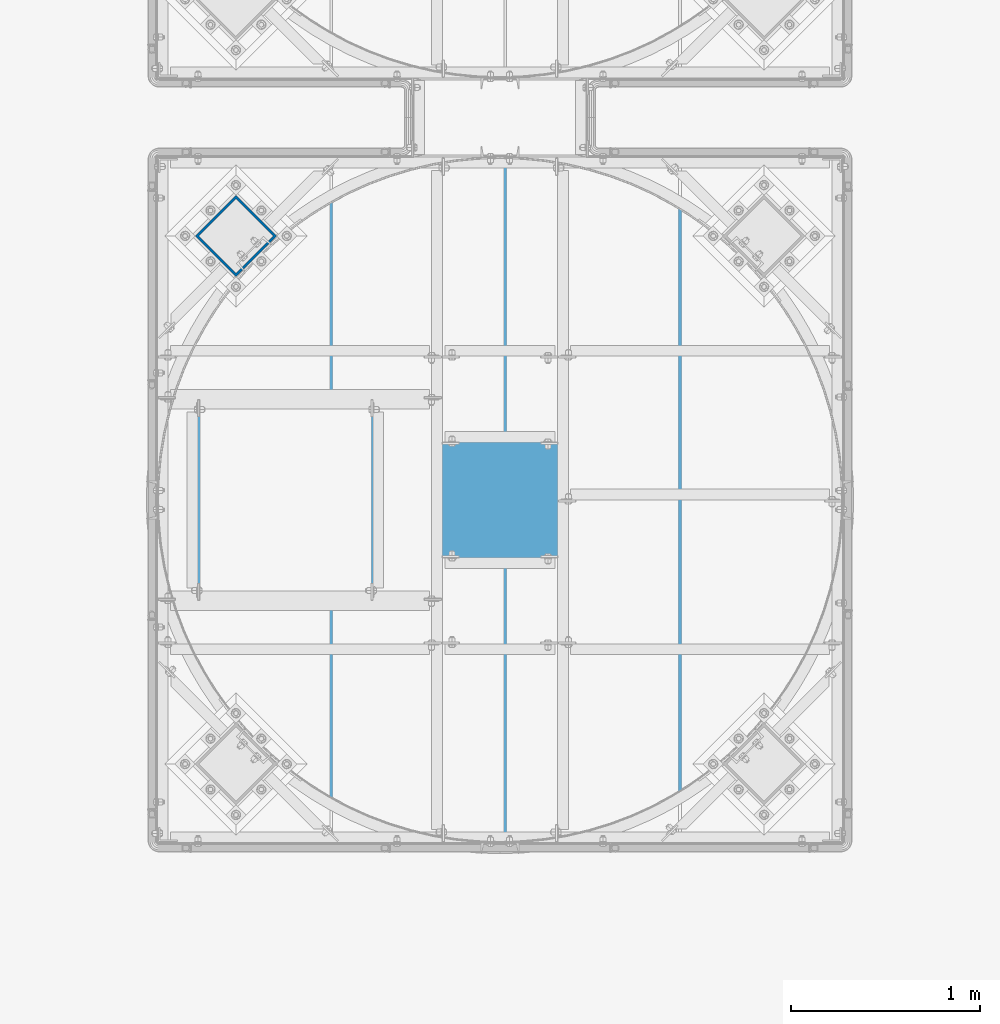
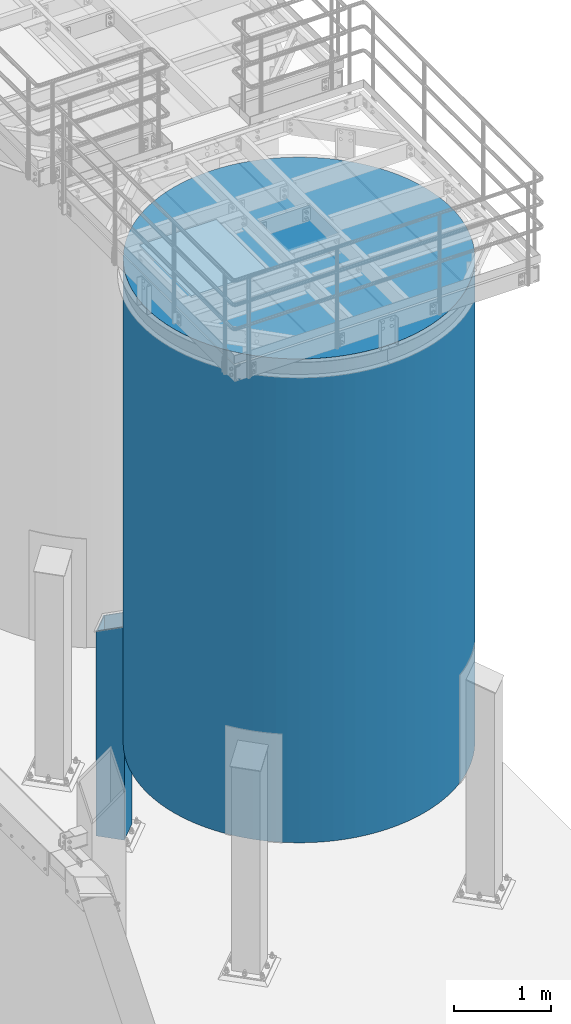
# One storey, part 548 of 1876: 2 columns, 2 elements without a shape of their own.
"""IFC2X3 building model written with IfcOpenShell, lengths in millimetres."""

from ifc_helpers import new_model, si_unit, frame, origin_with_axes, place, context, subcontext, project, spatial, faceted_brep, material, type_object, element, aggregate, save


model = new_model("IFC2X3")

# Units and contexts
model_context = context("Model", 3, precision=1e-05, world=origin_with_axes())
body_context = subcontext(model_context, "Body", "Model", "MODEL_VIEW")
ifc_project = project(units=[si_unit("LENGTHUNIT", "METRE", prefix="MILLI"), si_unit("AREAUNIT", "SQUARE_METRE"), si_unit("VOLUMEUNIT", "CUBIC_METRE"), si_unit("MASSUNIT", "GRAM", prefix="KILO"), si_unit("TIMEUNIT", "SECOND"), si_unit("PLANEANGLEUNIT", "RADIAN"), si_unit("SOLIDANGLEUNIT", "STERADIAN"), si_unit("THERMODYNAMICTEMPERATUREUNIT", "DEGREE_CELSIUS"), si_unit("LUMINOUSINTENSITYUNIT", "LUMEN")], contexts=[model_context])

# Site, building, storey
site_placement = place(None, origin_with_axes())
site = spatial("IfcSite", under=ifc_project, at=site_placement, CompositionType="ELEMENT")
building_placement = place(site_placement, origin_with_axes())
building = spatial("IfcBuilding", under=site, at=building_placement, Name="Undefined", CompositionType="ELEMENT")
storey_placement = place(building_placement, origin_with_axes())
storey = spatial("IfcBuildingStorey", under=building, at=storey_placement, Name="Undefined", CompositionType="ELEMENT", Elevation=0.0)

# Assembly, column
assembly_1_placement = place(storey_placement, origin_with_axes())
assembly_1 = element("IfcElementAssembly", 1, at=assembly_1_placement, inside=storey, Name="STORAGE TANK", AssemblyPlace="NOTDEFINED", PredefinedType="REINFORCEMENT_UNIT")
ifc_material_1 = material(Name="CONCRETE/3000")
column_type_1 = type_object("IfcColumnType", PredefinedType="NOTDEFINED")
column_1_placement = place(assembly_1_placement, frame((5181.60140708775, -13588.9644042969, 1524.0), z_axis=(-1.0, 0.0, 0.0), x_axis=(0.0, 0.0, 1.0)))
column_1 = element("IfcColumn", 2, at=column_1_placement, type_object=column_type_1, material=ifc_material_1, Name="STORAGE TANK", context=body_context, shape_type="Brep", body=[
    faceted_brep([(0.0, -1816.1, 0.0), (0.0, -1812.21159049363, -118.778622994864), (6096.0, -1812.21159049363, -118.778622994864), (6096.0, -1816.1, 0.0), (0.0, -1800.56301274098, -237.048617690837), (6096.0, -1800.56301274098, -237.048617690837), (0.0, -1781.20414774031, -354.303533813491), (6096.0, -1781.20414774031, -354.303533813491), (0.0, -1754.21789312358, -470.04126781069), (6096.0, -1754.21789312358, -470.04126781069), (0.0, -1719.71980817606, -583.766212937072), (6096.0, -1719.71980817606, -583.766212937072), (0.0, -1677.85761899375, -694.991381518241), (6096.0, -1677.85761899375, -694.991381518241), (0.0, -1628.81058589751, -803.24049030673), (6096.0, -1628.81058589751, -803.24049030673), (0.0, -1572.78873581292, -908.050000000001), (6096.0, -1572.78873581292, -908.050000000001), (0.0, -1510.03196290265, -1008.9711001869), (6096.0, -1510.03196290265, -1008.9711001869), (0.0, -1440.80900130291, -1105.57163122274), (6096.0, -1440.80900130291, -1105.57163122274), (0.0, -1365.41627436257, -1197.43793480324), (6096.0, -1365.41627436257, -1197.43793480324), (0.0, -1284.17662531289, -1284.17662531289), (6096.0, -1284.17662531289, -1284.17662531289), (0.0, -1197.43793480323, -1365.41627436257), (6096.0, -1197.43793480323, -1365.41627436257), (0.0, -1105.57163122274, -1440.80900130291), (6096.0, -1105.57163122274, -1440.80900130291), (0.0, -1008.9711001869, -1510.03196290265), (6096.0, -1008.9711001869, -1510.03196290265), (0.0, -908.049999999999, -1572.78873581292), (6096.0, -908.049999999999, -1572.78873581292), (0.0, -803.240490306727, -1628.81058589752), (6096.0, -803.240490306727, -1628.81058589752), (0.0, -694.991381518239, -1677.85761899375), (6096.0, -694.991381518239, -1677.85761899375), (0.0, -583.766212937071, -1719.71980817606), (6096.0, -583.766212937071, -1719.71980817606), (0.0, -470.041267810688, -1754.21789312358), (6096.0, -470.041267810688, -1754.21789312358), (0.0, -354.303533813489, -1781.20414774031), (6096.0, -354.303533813489, -1781.20414774031), (0.0, -237.048617690834, -1800.56301274098), (6096.0, -237.048617690834, -1800.56301274098), (0.0, -118.778622994862, -1812.21159049363), (6096.0, -118.778622994862, -1812.21159049363), (0.0, 0.0, -1816.1), (6096.0, 0.0, -1816.1), (0.0, 118.778622994863, -1812.21159049363), (6096.0, 118.778622994863, -1812.21159049363), (0.0, 237.048617690838, -1800.56301274098), (6096.0, 237.048617690838, -1800.56301274098), (0.0, 354.303533813491, -1781.20414774031), (6096.0, 354.303533813491, -1781.20414774031), (0.0, 470.04126781069, -1754.21789312358), (6096.0, 470.04126781069, -1754.21789312358), (0.0, 583.766212937073, -1719.71980817606), (6096.0, 583.766212937073, -1719.71980817606), (0.0, 694.991381518241, -1677.85761899375), (6096.0, 694.991381518241, -1677.85761899375), (0.0, 803.240490306729, -1628.81058589752), (6096.0, 803.240490306729, -1628.81058589752), (0.0, 908.050000000001, -1572.78873581292), (6096.0, 908.050000000001, -1572.78873581292), (0.0, 1008.9711001869, -1510.03196290265), (6096.0, 1008.9711001869, -1510.03196290265), (0.0, 1105.57163122274, -1440.80900130291), (6096.0, 1105.57163122274, -1440.80900130291), (0.0, 1197.43793480324, -1365.41627436257), (6096.0, 1197.43793480324, -1365.41627436257), (0.0, 1284.17662531289, -1284.17662531289), (6096.0, 1284.17662531289, -1284.17662531289), (0.0, 1365.41627436257, -1197.43793480323), (6096.0, 1365.41627436257, -1197.43793480323), (0.0, 1440.80900130291, -1105.57163122274), (6096.0, 1440.80900130291, -1105.57163122274), (0.0, 1510.03196290265, -1008.9711001869), (6096.0, 1510.03196290265, -1008.9711001869), (0.0, 1572.78873581292, -908.049999999999), (6096.0, 1572.78873581292, -908.049999999999), (0.0, 1628.81058589752, -803.240490306728), (6096.0, 1628.81058589752, -803.240490306728), (0.0, 1677.85761899375, -694.991381518238), (6096.0, 1677.85761899375, -694.991381518238), (0.0, 1719.71980817606, -583.766212937071), (6096.0, 1719.71980817606, -583.766212937071), (0.0, 1754.21789312358, -470.041267810687), (6096.0, 1754.21789312358, -470.041267810687), (0.0, 1781.20414774031, -354.30353381349), (6096.0, 1781.20414774031, -354.30353381349), (0.0, 1800.56301274098, -237.048617690835), (6096.0, 1800.56301274098, -237.048617690835), (0.0, 1812.21159049363, -118.778622994862), (6096.0, 1812.21159049363, -118.778622994862), (0.0, 1816.1, 0.0), (6096.0, 1816.1, 0.0), (0.0, 1812.21159049363, 118.778622994863), (6096.0, 1812.21159049363, 118.778622994863), (0.0, 1800.56301274098, 237.048617690836), (6096.0, 1800.56301274098, 237.048617690836), (0.0, 1781.20414774031, 354.303533813491), (6096.0, 1781.20414774031, 354.303533813491), (0.0, 1754.21789312358, 470.041267810689), (6096.0, 1754.21789312358, 470.041267810689), (0.0, 1719.71980817606, 583.766212937072), (6096.0, 1719.71980817606, 583.766212937072), (0.0, 1677.85761899375, 694.99138151824), (6096.0, 1677.85761899375, 694.99138151824), (0.0, 1628.81058589752, 803.240490306729), (6096.0, 1628.81058589752, 803.240490306729), (0.0, 1572.78873581292, 908.05), (6096.0, 1572.78873581292, 908.05), (0.0, 1510.03196290265, 1008.9711001869), (6096.0, 1510.03196290265, 1008.9711001869), (0.0, 1440.80900130291, 1105.57163122274), (6096.0, 1440.80900130291, 1105.57163122274), (0.0, 1365.41627436257, 1197.43793480324), (6096.0, 1365.41627436257, 1197.43793480324), (0.0, 1284.17662531289, 1284.17662531289), (6096.0, 1284.17662531289, 1284.17662531289), (0.0, 1197.43793480323, 1365.41627436257), (6096.0, 1197.43793480323, 1365.41627436257), (0.0, 1105.57163122274, 1440.80900130291), (6096.0, 1105.57163122274, 1440.80900130291), (0.0, 1008.9711001869, 1510.03196290265), (6096.0, 1008.9711001869, 1510.03196290265), (0.0, 908.049999999999, 1572.78873581292), (6096.0, 908.049999999999, 1572.78873581292), (0.0, 803.240490306727, 1628.81058589752), (6096.0, 803.240490306727, 1628.81058589752), (0.0, 694.991381518239, 1677.85761899375), (6096.0, 694.991381518239, 1677.85761899375), (0.0, 583.766212937071, 1719.71980817606), (6096.0, 583.766212937071, 1719.71980817606), (0.0, 470.041267810688, 1754.21789312358), (6096.0, 470.041267810688, 1754.21789312358), (0.0, 354.303533813491, 1781.20414774031), (6096.0, 354.303533813491, 1781.20414774031), (0.0, 237.048617690836, 1800.56301274098), (6096.0, 237.048617690836, 1800.56301274098), (0.0, 118.778622994863, 1812.21159049363), (6096.0, 118.778622994863, 1812.21159049363), (0.0, 0.0, 1816.1), (6096.0, 0.0, 1816.1), (0.0, -118.778622994863, 1812.21159049363), (6096.0, -118.778622994863, 1812.21159049363), (0.0, -237.048617690836, 1800.56301274098), (6096.0, -237.048617690836, 1800.56301274098), (0.0, -354.303533813491, 1781.20414774031), (6096.0, -354.303533813491, 1781.20414774031), (0.0, -470.041267810688, 1754.21789312358), (6096.0, -470.041267810688, 1754.21789312358), (0.0, -583.766212937071, 1719.71980817606), (6096.0, -583.766212937071, 1719.71980817606), (0.0, -694.991381518239, 1677.85761899375), (6096.0, -694.991381518239, 1677.85761899375), (0.0, -803.240490306729, 1628.81058589752), (6096.0, -803.240490306729, 1628.81058589752), (0.0, -908.050000000001, 1572.78873581292), (6096.0, -908.050000000001, 1572.78873581292), (0.0, -1008.9711001869, 1510.03196290265), (6096.0, -1008.9711001869, 1510.03196290265), (0.0, -1105.57163122274, 1440.80900130291), (6096.0, -1105.57163122274, 1440.80900130291), (0.0, -1197.43793480323, 1365.41627436257), (6096.0, -1197.43793480323, 1365.41627436257), (0.0, -1284.17662531289, 1284.17662531289), (6096.0, -1284.17662531289, 1284.17662531289), (0.0, -1365.41627436257, 1197.43793480324), (6096.0, -1365.41627436257, 1197.43793480324), (0.0, -1440.80900130291, 1105.57163122274), (6096.0, -1440.80900130291, 1105.57163122274), (0.0, -1510.03196290265, 1008.9711001869), (6096.0, -1510.03196290265, 1008.9711001869), (0.0, -1572.78873581292, 908.05), (6096.0, -1572.78873581292, 908.05), (0.0, -1628.81058589752, 803.240490306728), (6096.0, -1628.81058589752, 803.240490306728), (0.0, -1677.85761899375, 694.99138151824), (6096.0, -1677.85761899375, 694.99138151824), (0.0, -1719.71980817606, 583.766212937072), (6096.0, -1719.71980817606, 583.766212937072), (0.0, -1754.21789312358, 470.041267810688), (6096.0, -1754.21789312358, 470.041267810688), (0.0, -1781.20414774031, 354.303533813491), (6096.0, -1781.20414774031, 354.303533813491), (0.0, -1800.56301274098, 237.048617690835), (6096.0, -1800.56301274098, 237.048617690835), (0.0, -1812.21159049363, 118.778622994862), (6096.0, -1812.21159049363, 118.778622994862)], [[[0, 1, 2, 3]], [[1, 4, 5, 2]], [[4, 6, 7, 5]], [[6, 8, 9, 7]], [[8, 10, 11, 9]], [[10, 12, 13, 11]], [[12, 14, 15, 13]], [[14, 16, 17, 15]], [[16, 18, 19, 17]], [[18, 20, 21, 19]], [[20, 22, 23, 21]], [[22, 24, 25, 23]], [[24, 26, 27, 25]], [[26, 28, 29, 27]], [[28, 30, 31, 29]], [[30, 32, 33, 31]], [[32, 34, 35, 33]], [[34, 36, 37, 35]], [[36, 38, 39, 37]], [[38, 40, 41, 39]], [[40, 42, 43, 41]], [[42, 44, 45, 43]], [[44, 46, 47, 45]], [[46, 48, 49, 47]], [[48, 50, 51, 49]], [[50, 52, 53, 51]], [[52, 54, 55, 53]], [[54, 56, 57, 55]], [[56, 58, 59, 57]], [[58, 60, 61, 59]], [[60, 62, 63, 61]], [[62, 64, 65, 63]], [[64, 66, 67, 65]], [[66, 68, 69, 67]], [[68, 70, 71, 69]], [[70, 72, 73, 71]], [[72, 74, 75, 73]], [[74, 76, 77, 75]], [[76, 78, 79, 77]], [[78, 80, 81, 79]], [[80, 82, 83, 81]], [[82, 84, 85, 83]], [[84, 86, 87, 85]], [[86, 88, 89, 87]], [[88, 90, 91, 89]], [[90, 92, 93, 91]], [[92, 94, 95, 93]], [[94, 96, 97, 95]], [[96, 98, 99, 97]], [[98, 100, 101, 99]], [[100, 102, 103, 101]], [[102, 104, 105, 103]], [[104, 106, 107, 105]], [[106, 108, 109, 107]], [[108, 110, 111, 109]], [[110, 112, 113, 111]], [[112, 114, 115, 113]], [[114, 116, 117, 115]], [[116, 118, 119, 117]], [[118, 120, 121, 119]], [[120, 122, 123, 121]], [[122, 124, 125, 123]], [[124, 126, 127, 125]], [[126, 128, 129, 127]], [[128, 130, 131, 129]], [[130, 132, 133, 131]], [[132, 134, 135, 133]], [[134, 136, 137, 135]], [[136, 138, 139, 137]], [[138, 140, 141, 139]], [[140, 142, 143, 141]], [[142, 144, 145, 143]], [[144, 146, 147, 145]], [[146, 148, 149, 147]], [[148, 150, 151, 149]], [[150, 152, 153, 151]], [[152, 154, 155, 153]], [[154, 156, 157, 155]], [[156, 158, 159, 157]], [[158, 160, 161, 159]], [[160, 162, 163, 161]], [[162, 164, 165, 163]], [[164, 166, 167, 165]], [[166, 168, 169, 167]], [[168, 170, 171, 169]], [[170, 172, 173, 171]], [[172, 174, 175, 173]], [[174, 176, 177, 175]], [[176, 178, 179, 177]], [[178, 180, 181, 179]], [[180, 182, 183, 181]], [[182, 184, 185, 183]], [[184, 186, 187, 185]], [[186, 188, 189, 187]], [[188, 190, 191, 189]], [[190, 0, 3, 191]], [[5, 7, 9, 11, 13, 15, 17, 19, 21, 23, 25, 27, 29, 31, 33, 35, 37, 39, 41, 43, 45, 47, 49, 51, 53, 55, 57, 59, 61, 63, 65, 67, 69, 71, 73, 75, 77, 79, 81, 83, 85, 87, 89, 91, 93, 95, 97, 99, 101, 103, 105, 107, 109, 111, 113, 115, 117, 119, 121, 123, 125, 127, 129, 131, 133, 135, 137, 139, 141, 143, 145, 147, 149, 151, 153, 155, 157, 159, 161, 163, 165, 167, 169, 171, 173, 175, 177, 179, 181, 183, 185, 187, 189, 191, 3, 2]], [[190, 188, 186, 184, 182, 180, 178, 176, 174, 172, 170, 168, 166, 164, 162, 160, 158, 156, 154, 152, 150, 148, 146, 144, 142, 140, 138, 136, 134, 132, 130, 128, 126, 124, 122, 120, 118, 116, 114, 112, 110, 108, 106, 104, 102, 100, 98, 96, 94, 92, 90, 88, 86, 84, 82, 80, 78, 76, 74, 72, 70, 68, 66, 64, 62, 60, 58, 56, 54, 52, 50, 48, 46, 44, 42, 40, 38, 36, 34, 32, 30, 28, 26, 24, 22, 20, 18, 16, 14, 12, 10, 8, 6, 4, 1, 0]]]),
])
aggregate(assembly_1, [column_1])

assembly_2_placement = place(storey_placement, origin_with_axes())
assembly_2 = element("IfcElementAssembly", 3, at=assembly_2_placement, inside=storey, Name="COLUMN", AssemblyPlace="NOTDEFINED", PredefinedType="RIGID_FRAME")
ifc_material_2 = material()
column_type_2 = type_object("IfcColumnType", Name="HSS12X12X1/2", PredefinedType="NOTDEFINED")
column_2_placement = place(assembly_2_placement, frame((3783.01287936518, -12190.2703789189, 0.0), z_axis=(-0.707106781186547, -0.707106781186548, 0.0), x_axis=(0.0, 0.0, 1.0)))
column_2 = element("IfcColumn", 4, at=column_2_placement, type_object=column_type_2, material=ifc_material_2, Name="COLUMN", ObjectType="HSS12X12X1/2", context=body_context, shape_type="Brep", body=[
    faceted_brep([(57.15, 139.700000000023, -139.700000000023), (57.15, -139.700000000026, -139.700000000023), (2738.57757814383, -139.700000000026, -139.700000000022), (2636.8842951776, 139.700000000023, -139.700000000023), (57.15, -139.700000000026, 139.700000000026), (2738.57757814383, -139.700000000026, 139.700000000024), (57.15, 139.700000000021, 139.700000000025), (2636.8842951776, 139.700000000021, 139.700000000025), (57.15, 152.400000000023, -152.400000000025), (57.15, 152.400000000023, 152.400000000027), (2632.26187322459, 152.400000000023, 152.400000000028), (2632.26187322459, 152.400000000023, -152.400000000025), (57.15, -152.400000000031, 152.400000000027), (2743.20000009684, -152.400000000027, 152.400000000027), (57.15, -152.400000000027, -152.400000000024), (2743.20000009684, -152.400000000029, -152.400000000024)], [[[0, 1, 2, 3]], [[1, 4, 5, 2]], [[4, 6, 7, 5]], [[6, 0, 3, 7]], [[8, 9, 10, 11]], [[9, 12, 13, 10]], [[12, 14, 15, 13]], [[14, 8, 11, 15]], [[13, 15, 11, 10], [5, 7, 3, 2]], [[14, 12, 9, 8], [6, 4, 1, 0]]]),
])
aggregate(assembly_2, [column_2])

save(model, "model.ifc")
